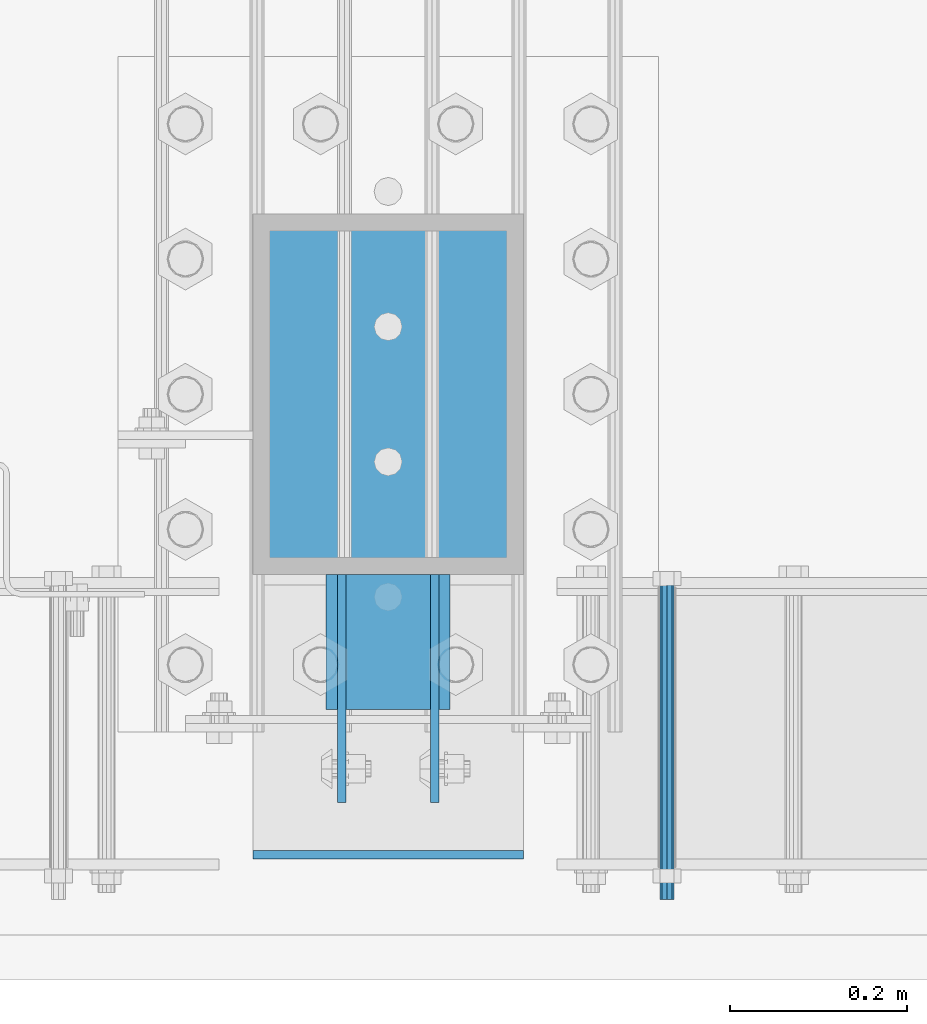
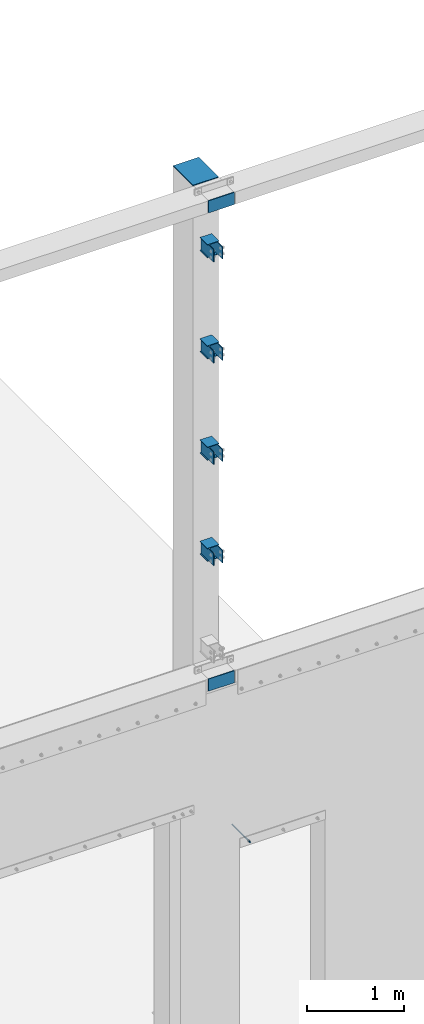
# One storey, part 1085 of 1876: 20 beams, 2 elements without a shape of their own.
"""IFC2X3 building model written with IfcOpenShell, lengths in millimetres."""

from ifc_helpers import new_model, si_unit, frame, origin_with_axes, place, context, subcontext, project, spatial, faceted_brep, material, type_object, element, aggregate, save


model = new_model("IFC2X3")

# Units and contexts
model_context = context("Model", 3, precision=1e-05, world=origin_with_axes())
body_context = subcontext(model_context, "Body", "Model", "MODEL_VIEW")
ifc_project = project(units=[si_unit("LENGTHUNIT", "METRE", prefix="MILLI"), si_unit("AREAUNIT", "SQUARE_METRE"), si_unit("VOLUMEUNIT", "CUBIC_METRE"), si_unit("MASSUNIT", "GRAM", prefix="KILO"), si_unit("TIMEUNIT", "SECOND"), si_unit("PLANEANGLEUNIT", "RADIAN"), si_unit("SOLIDANGLEUNIT", "STERADIAN"), si_unit("THERMODYNAMICTEMPERATUREUNIT", "DEGREE_CELSIUS"), si_unit("LUMINOUSINTENSITYUNIT", "LUMEN")], contexts=[model_context])

# Site, building, storey
site_placement = place(None, origin_with_axes())
site = spatial("IfcSite", under=ifc_project, at=site_placement, CompositionType="ELEMENT")
building_placement = place(site_placement, origin_with_axes())
building = spatial("IfcBuilding", under=site, at=building_placement, Name="Undefined", CompositionType="ELEMENT")
storey_placement = place(building_placement, origin_with_axes())
storey = spatial("IfcBuildingStorey", under=building, at=storey_placement, Name="Undefined", CompositionType="ELEMENT", Elevation=0.0)

# Assembly, beams
assembly_1_placement = place(storey_placement, origin_with_axes())
assembly_1 = element("IfcElementAssembly", 1, at=assembly_1_placement, inside=storey, Name="COLUMN", AssemblyPlace="NOTDEFINED", PredefinedType="RIGID_FRAME")
ifc_material = material(Name="STEEL/A36")
beam_type_1 = type_object("IfcBeamType", PredefinedType="NOTDEFINED")
beam_1_placement = place(assembly_1_placement, frame((3836.98749847411, -25603.2, 6097.5875), z_axis=(0.0, 0.0, -1.0), x_axis=(0.0, -1.0, 0.0)))
beam_1 = element("IfcBeam", 2, at=beam_1_placement, type_object=beam_type_1, material=ifc_material, Name="PLATE", context=body_context, shape_type="Brep", body=[
    faceted_brep([(0.0, 4.76249999999982, -76.1999999999998), (3.63797880709171e-12, 4.76249999999982, 76.1999969482422), (257.174999999999, 4.76249999999982, 76.1999999999998), (257.174999999999, 4.76249999999982, -76.1999999999998), (3.63797880709171e-12, -4.76249999999982, 76.1999969482422), (257.174999999999, -4.76249999999982, 76.1999999999998), (0.0, -4.76249999999982, -76.1999999999998), (257.174999999999, -4.76249999999982, -76.1999999999998)], [[[0, 1, 2, 3]], [[1, 4, 5, 2]], [[4, 6, 7, 5]], [[6, 0, 3, 7]], [[5, 7, 3, 2]], [[6, 4, 1, 0]]]),
])
beam_2_placement = place(assembly_1_placement, frame((3836.98749847411, -25603.2, 7366.52916666666), z_axis=(0.0, 0.0, -1.0), x_axis=(0.0, -1.0, 0.0)))
beam_2 = element("IfcBeam", 3, at=beam_2_placement, type_object=beam_type_1, material=ifc_material, Name="PLATE", context=body_context, shape_type="Brep", body=[
    faceted_brep([(0.0, 4.76249999999982, -76.1999999999998), (3.63797880709171e-12, 4.76249999999982, 76.1999969482422), (257.174999999999, 4.76249999999982, 76.1999999999998), (257.174999999999, 4.76249999999982, -76.1999999999998), (3.63797880709171e-12, -4.76249999999982, 76.1999969482422), (257.174999999999, -4.76249999999982, 76.1999999999998), (0.0, -4.76249999999982, -76.1999999999998), (257.174999999999, -4.76249999999982, -76.1999999999998)], [[[0, 1, 2, 3]], [[1, 4, 5, 2]], [[4, 6, 7, 5]], [[6, 0, 3, 7]], [[5, 7, 3, 2]], [[6, 4, 1, 0]]]),
])
beam_3_placement = place(assembly_1_placement, frame((3836.98749847411, -25603.2, 8635.47083333333), z_axis=(0.0, 0.0, -1.0), x_axis=(0.0, -1.0, 0.0)))
beam_3 = element("IfcBeam", 4, at=beam_3_placement, type_object=beam_type_1, material=ifc_material, Name="PLATE", context=body_context, shape_type="Brep", body=[
    faceted_brep([(0.0, 4.76249999999982, -76.1999999999998), (3.63797880709171e-12, 4.76249999999982, 76.1999969482422), (257.174999999999, 4.76249999999982, 76.1999999999998), (257.174999999999, 4.76249999999982, -76.1999999999998), (3.63797880709171e-12, -4.76249999999982, 76.1999969482422), (257.174999999999, -4.76249999999982, 76.1999999999998), (0.0, -4.76249999999982, -76.1999999999998), (257.174999999999, -4.76249999999982, -76.1999999999998)], [[[0, 1, 2, 3]], [[1, 4, 5, 2]], [[4, 6, 7, 5]], [[6, 0, 3, 7]], [[5, 7, 3, 2]], [[6, 4, 1, 0]]]),
])
beam_4_placement = place(assembly_1_placement, frame((3836.98749847411, -25603.2, 9904.41249999999), z_axis=(0.0, 0.0, -1.0), x_axis=(0.0, -1.0, 0.0)))
beam_4 = element("IfcBeam", 5, at=beam_4_placement, type_object=beam_type_1, material=ifc_material, Name="PLATE", context=body_context, shape_type="Brep", body=[
    faceted_brep([(0.0, 4.76249999999982, -76.1999999999998), (3.63797880709171e-12, 4.76249999999982, 76.1999969482422), (257.174999999999, 4.76249999999982, 76.1999999999998), (257.174999999999, 4.76249999999982, -76.1999999999998), (3.63797880709171e-12, -4.76249999999982, 76.1999969482422), (257.174999999999, -4.76249999999982, 76.1999999999998), (0.0, -4.76249999999982, -76.1999999999998), (257.174999999999, -4.76249999999982, -76.1999999999998)], [[[0, 1, 2, 3]], [[1, 4, 5, 2]], [[4, 6, 7, 5]], [[6, 0, 3, 7]], [[5, 7, 3, 2]], [[6, 4, 1, 0]]]),
])
beam_5_placement = place(assembly_1_placement, frame((3941.76249999999, -25603.2, 6097.5875), z_axis=(0.0, 0.0, -1.0), x_axis=(0.0, -1.0, 0.0)))
beam_5 = element("IfcBeam", 6, at=beam_5_placement, type_object=beam_type_1, material=ifc_material, Name="PLATE", context=body_context, shape_type="Brep", body=[
    faceted_brep([(0.0, 4.76249999999982, -76.1999999999998), (3.63797880709171e-12, 4.76249999999982, 76.1999969482422), (257.174999999999, 4.76249999999982, 76.1999999999998), (257.174999999999, 4.76249999999982, -76.1999999999998), (3.63797880709171e-12, -4.76249999999982, 76.1999969482422), (257.174999999999, -4.76249999999982, 76.1999999999998), (0.0, -4.76249999999982, -76.1999999999998), (257.174999999999, -4.76249999999982, -76.1999999999998)], [[[0, 1, 2, 3]], [[1, 4, 5, 2]], [[4, 6, 7, 5]], [[6, 0, 3, 7]], [[5, 7, 3, 2]], [[6, 4, 1, 0]]]),
])
beam_6_placement = place(assembly_1_placement, frame((3941.76249999999, -25603.2, 7366.52916666666), z_axis=(0.0, 0.0, -1.0), x_axis=(0.0, -1.0, 0.0)))
beam_6 = element("IfcBeam", 7, at=beam_6_placement, type_object=beam_type_1, material=ifc_material, Name="PLATE", context=body_context, shape_type="Brep", body=[
    faceted_brep([(0.0, 4.76249999999982, -76.1999999999998), (3.63797880709171e-12, 4.76249999999982, 76.1999969482422), (257.174999999999, 4.76249999999982, 76.1999999999998), (257.174999999999, 4.76249999999982, -76.1999999999998), (3.63797880709171e-12, -4.76249999999982, 76.1999969482422), (257.174999999999, -4.76249999999982, 76.1999999999998), (0.0, -4.76249999999982, -76.1999999999998), (257.174999999999, -4.76249999999982, -76.1999999999998)], [[[0, 1, 2, 3]], [[1, 4, 5, 2]], [[4, 6, 7, 5]], [[6, 0, 3, 7]], [[5, 7, 3, 2]], [[6, 4, 1, 0]]]),
])
beam_7_placement = place(assembly_1_placement, frame((3941.76249999999, -25603.2, 8635.47083333333), z_axis=(0.0, 0.0, -1.0), x_axis=(0.0, -1.0, 0.0)))
beam_7 = element("IfcBeam", 8, at=beam_7_placement, type_object=beam_type_1, material=ifc_material, Name="PLATE", context=body_context, shape_type="Brep", body=[
    faceted_brep([(0.0, 4.76249999999982, -76.1999999999998), (3.63797880709171e-12, 4.76249999999982, 76.1999969482422), (257.174999999999, 4.76249999999982, 76.1999999999998), (257.174999999999, 4.76249999999982, -76.1999999999998), (3.63797880709171e-12, -4.76249999999982, 76.1999969482422), (257.174999999999, -4.76249999999982, 76.1999999999998), (0.0, -4.76249999999982, -76.1999999999998), (257.174999999999, -4.76249999999982, -76.1999999999998)], [[[0, 1, 2, 3]], [[1, 4, 5, 2]], [[4, 6, 7, 5]], [[6, 0, 3, 7]], [[5, 7, 3, 2]], [[6, 4, 1, 0]]]),
])
beam_8_placement = place(assembly_1_placement, frame((3941.76249999999, -25603.2, 9904.41249999999), z_axis=(0.0, 0.0, -1.0), x_axis=(0.0, -1.0, 0.0)))
beam_8 = element("IfcBeam", 9, at=beam_8_placement, type_object=beam_type_1, material=ifc_material, Name="PLATE", context=body_context, shape_type="Brep", body=[
    faceted_brep([(0.0, 4.76249999999982, -76.1999999999998), (3.63797880709171e-12, 4.76249999999982, 76.1999969482422), (257.174999999999, 4.76249999999982, 76.1999999999998), (257.174999999999, 4.76249999999982, -76.1999999999998), (3.63797880709171e-12, -4.76249999999982, 76.1999969482422), (257.174999999999, -4.76249999999982, 76.1999999999998), (0.0, -4.76249999999982, -76.1999999999998), (257.174999999999, -4.76249999999982, -76.1999999999998)], [[[0, 1, 2, 3]], [[1, 4, 5, 2]], [[4, 6, 7, 5]], [[6, 0, 3, 7]], [[5, 7, 3, 2]], [[6, 4, 1, 0]]]),
])
beam_9_placement = place(assembly_1_placement, frame((4041.775, -25919.1125, 4597.4), z_axis=(0.0, 0.0, 1.0), x_axis=(-1.0, 0.0, 0.0)))
beam_9 = element("IfcBeam", 10, at=beam_9_placement, type_object=beam_type_1, material=ifc_material, Name="PLATE", context=body_context, shape_type="Brep", body=[
    faceted_brep([(0.0, 4.76249999999982, -76.1999999999998), (3.63797880709171e-12, 4.76249999999982, 76.1999969482422), (304.799999999999, 4.76250000000073, 76.1999999999998), (304.799999999999, 4.76250000000073, -76.1999999999998), (3.63797880709171e-12, -4.76249999999982, 76.1999969482422), (304.799999999999, -4.76250000000073, 76.1999999999998), (0.0, -4.76249999999982, -76.1999999999998), (304.799999999999, -4.76250000000073, -76.1999999999998)], [[[0, 1, 2, 3]], [[1, 4, 5, 2]], [[4, 6, 7, 5]], [[6, 0, 3, 7]], [[5, 7, 3, 2]], [[6, 4, 1, 0]]]),
])
beam_10_placement = place(assembly_1_placement, frame((4041.775, -25919.1125, 10591.8), z_axis=(0.0, 0.0, 1.0), x_axis=(-1.0, 0.0, 0.0)))
beam_10 = element("IfcBeam", 11, at=beam_10_placement, type_object=beam_type_1, material=ifc_material, Name="PLATE", context=body_context, shape_type="Brep", body=[
    faceted_brep([(0.0, 4.76249999999982, -76.1999999999998), (3.63797880709171e-12, 4.76249999999982, 76.1999969482422), (304.799999999999, 4.76250000000073, 76.1999999999998), (304.799999999999, 4.76250000000073, -76.1999999999998), (3.63797880709171e-12, -4.76249999999982, 76.1999969482422), (304.799999999999, -4.76250000000073, 76.1999999999998), (0.0, -4.76249999999982, -76.1999999999998), (304.799999999999, -4.76250000000073, -76.1999999999998)], [[[0, 1, 2, 3]], [[1, 4, 5, 2]], [[4, 6, 7, 5]], [[6, 0, 3, 7]], [[5, 7, 3, 2]], [[6, 4, 1, 0]]]),
])
beam_type_2 = type_object("IfcBeamType", PredefinedType="NOTDEFINED")
beam_11_placement = place(assembly_1_placement, frame((3889.375, -25603.2, 9825.0375), z_axis=(1.0, 0.0, 0.0), x_axis=(0.0, -1.0, 0.0)))
beam_11 = element("IfcBeam", 12, at=beam_11_placement, type_object=beam_type_2, material=ifc_material, Name="PLATE", context=body_context, shape_type="Brep", body=[
    faceted_brep([(0.0, 3.17500000000018, -69.8499999999999), (0.0, 3.17500000000018, 69.8499999999999), (152.400000000001, 3.17500000000018, 69.8499999999999), (152.400000000001, 3.17500000000018, -69.8499999999999), (0.0, -3.17500000000018, 69.8499999999999), (152.400000000001, -3.17500000000018, 69.8499999999999), (0.0, -3.17500000000018, -69.8499999999999), (152.400000000001, -3.17500000000018, -69.8499999999999)], [[[0, 1, 2, 3]], [[1, 4, 5, 2]], [[4, 6, 7, 5]], [[6, 0, 3, 7]], [[5, 7, 3, 2]], [[6, 4, 1, 0]]]),
])
beam_12_placement = place(assembly_1_placement, frame((3889.375, -25603.2, 9983.78749999999), z_axis=(1.0, 0.0, 0.0), x_axis=(0.0, -1.0, 0.0)))
beam_12 = element("IfcBeam", 13, at=beam_12_placement, type_object=beam_type_2, material=ifc_material, Name="PLATE", context=body_context, shape_type="Brep", body=[
    faceted_brep([(0.0, 3.17500000000018, -69.8499999999999), (0.0, 3.17500000000018, 69.8499999999999), (152.400000000001, 3.17500000000018, 69.8499999999999), (152.400000000001, 3.17500000000018, -69.8499999999999), (0.0, -3.17500000000018, 69.8499999999999), (152.400000000001, -3.17500000000018, 69.8499999999999), (0.0, -3.17500000000018, -69.8499999999999), (152.400000000001, -3.17500000000018, -69.8499999999999)], [[[0, 1, 2, 3]], [[1, 4, 5, 2]], [[4, 6, 7, 5]], [[6, 0, 3, 7]], [[5, 7, 3, 2]], [[6, 4, 1, 0]]]),
])
beam_13_placement = place(assembly_1_placement, frame((3889.375, -25603.2, 8556.09583333333), z_axis=(1.0, 0.0, 0.0), x_axis=(0.0, -1.0, 0.0)))
beam_13 = element("IfcBeam", 14, at=beam_13_placement, type_object=beam_type_2, material=ifc_material, Name="PLATE", context=body_context, shape_type="Brep", body=[
    faceted_brep([(0.0, 3.17500000000018, -69.8499999999999), (0.0, 3.17500000000018, 69.8499999999999), (152.400000000001, 3.17500000000018, 69.8499999999999), (152.400000000001, 3.17500000000018, -69.8499999999999), (0.0, -3.17500000000018, 69.8499999999999), (152.400000000001, -3.17500000000018, 69.8499999999999), (0.0, -3.17500000000018, -69.8499999999999), (152.400000000001, -3.17500000000018, -69.8499999999999)], [[[0, 1, 2, 3]], [[1, 4, 5, 2]], [[4, 6, 7, 5]], [[6, 0, 3, 7]], [[5, 7, 3, 2]], [[6, 4, 1, 0]]]),
])
beam_14_placement = place(assembly_1_placement, frame((3889.375, -25603.2, 8714.84583333333), z_axis=(1.0, 0.0, 0.0), x_axis=(0.0, -1.0, 0.0)))
beam_14 = element("IfcBeam", 15, at=beam_14_placement, type_object=beam_type_2, material=ifc_material, Name="PLATE", context=body_context, shape_type="Brep", body=[
    faceted_brep([(0.0, 3.17500000000018, -69.8499999999999), (0.0, 3.17500000000018, 69.8499999999999), (152.400000000001, 3.17500000000018, 69.8499999999999), (152.400000000001, 3.17500000000018, -69.8499999999999), (0.0, -3.17500000000018, 69.8499999999999), (152.400000000001, -3.17500000000018, 69.8499999999999), (0.0, -3.17500000000018, -69.8499999999999), (152.400000000001, -3.17500000000018, -69.8499999999999)], [[[0, 1, 2, 3]], [[1, 4, 5, 2]], [[4, 6, 7, 5]], [[6, 0, 3, 7]], [[5, 7, 3, 2]], [[6, 4, 1, 0]]]),
])
beam_15_placement = place(assembly_1_placement, frame((3889.375, -25603.2, 7287.15416666666), z_axis=(1.0, 0.0, 0.0), x_axis=(0.0, -1.0, 0.0)))
beam_15 = element("IfcBeam", 16, at=beam_15_placement, type_object=beam_type_2, material=ifc_material, Name="PLATE", context=body_context, shape_type="Brep", body=[
    faceted_brep([(0.0, 3.17500000000018, -69.8499999999999), (0.0, 3.17500000000018, 69.8499999999999), (152.400000000001, 3.17500000000018, 69.8499999999999), (152.400000000001, 3.17500000000018, -69.8499999999999), (0.0, -3.17500000000018, 69.8499999999999), (152.400000000001, -3.17500000000018, 69.8499999999999), (0.0, -3.17500000000018, -69.8499999999999), (152.400000000001, -3.17500000000018, -69.8499999999999)], [[[0, 1, 2, 3]], [[1, 4, 5, 2]], [[4, 6, 7, 5]], [[6, 0, 3, 7]], [[5, 7, 3, 2]], [[6, 4, 1, 0]]]),
])
beam_16_placement = place(assembly_1_placement, frame((3889.375, -25603.2, 7445.90416666666), z_axis=(1.0, 0.0, 0.0), x_axis=(0.0, -1.0, 0.0)))
beam_16 = element("IfcBeam", 17, at=beam_16_placement, type_object=beam_type_2, material=ifc_material, Name="PLATE", context=body_context, shape_type="Brep", body=[
    faceted_brep([(0.0, 3.17500000000018, -69.8499999999999), (0.0, 3.17500000000018, 69.8499999999999), (152.400000000001, 3.17500000000018, 69.8499999999999), (152.400000000001, 3.17500000000018, -69.8499999999999), (0.0, -3.17500000000018, 69.8499999999999), (152.400000000001, -3.17500000000018, 69.8499999999999), (0.0, -3.17500000000018, -69.8499999999999), (152.400000000001, -3.17500000000018, -69.8499999999999)], [[[0, 1, 2, 3]], [[1, 4, 5, 2]], [[4, 6, 7, 5]], [[6, 0, 3, 7]], [[5, 7, 3, 2]], [[6, 4, 1, 0]]]),
])
beam_17_placement = place(assembly_1_placement, frame((3889.375, -25603.2, 6018.2125), z_axis=(1.0, 0.0, 0.0), x_axis=(0.0, -1.0, 0.0)))
beam_17 = element("IfcBeam", 18, at=beam_17_placement, type_object=beam_type_2, material=ifc_material, Name="PLATE", context=body_context, shape_type="Brep", body=[
    faceted_brep([(0.0, 3.17500000000018, -69.8499999999999), (0.0, 3.17500000000018, 69.8499999999999), (152.400000000001, 3.17500000000018, 69.8499999999999), (152.400000000001, 3.17500000000018, -69.8499999999999), (0.0, -3.17500000000018, 69.8499999999999), (152.400000000001, -3.17500000000018, 69.8499999999999), (0.0, -3.17500000000018, -69.8499999999999), (152.400000000001, -3.17500000000018, -69.8499999999999)], [[[0, 1, 2, 3]], [[1, 4, 5, 2]], [[4, 6, 7, 5]], [[6, 0, 3, 7]], [[5, 7, 3, 2]], [[6, 4, 1, 0]]]),
])
beam_18_placement = place(assembly_1_placement, frame((3889.375, -25603.2, 6176.9625), z_axis=(1.0, 0.0, 0.0), x_axis=(0.0, -1.0, 0.0)))
beam_18 = element("IfcBeam", 19, at=beam_18_placement, type_object=beam_type_2, material=ifc_material, Name="PLATE", context=body_context, shape_type="Brep", body=[
    faceted_brep([(0.0, 3.17500000000018, -69.8499999999999), (0.0, 3.17500000000018, 69.8499999999999), (152.400000000001, 3.17500000000018, 69.8499999999999), (152.400000000001, 3.17500000000018, -69.8499999999999), (0.0, -3.17500000000018, 69.8499999999999), (152.400000000001, -3.17500000000018, 69.8499999999999), (0.0, -3.17500000000018, -69.8499999999999), (152.400000000001, -3.17500000000018, -69.8499999999999)], [[[0, 1, 2, 3]], [[1, 4, 5, 2]], [[4, 6, 7, 5]], [[6, 0, 3, 7]], [[5, 7, 3, 2]], [[6, 4, 1, 0]]]),
])

# Assembly, beam
assembly_2_placement = place(storey_placement, origin_with_axes())
assembly_2 = element("IfcElementAssembly", 20, at=assembly_2_placement, inside=storey, Name="ANCHOR_BOLT", AssemblyPlace="NOTDEFINED", PredefinedType="RIGID_FRAME")
beam_type_3 = type_object("IfcBeamType", PredefinedType="NOTDEFINED")
beam_19_placement = place(assembly_2_placement, frame((4203.70979190826, -25969.9124969811, 2493.96240386963), z_axis=(0.0, 0.0, 1.0), x_axis=(-2.91149999876944e-05, 0.999999999576158, 0.0)))
beam_19 = element("IfcBeam", 21, at=beam_19_placement, type_object=beam_type_3, material=ifc_material, Name="ANCHOR_BOLT", context=body_context, shape_type="Brep", body=[
    faceted_brep([(0.0, -7.9375, 0.0), (0.0, -5.61266007566822, -5.61266007566883), (369.887490732475, -5.61266007567792, -5.61266007566837), (369.887490732477, -7.93750000000978, 0.0), (0.0, 0.0, -7.9375), (369.88749073247, -9.54969436861575e-12, -7.9375), (0.0, 5.61266007566822, -5.61266007566883), (369.887490732464, 5.6126600756586, -5.61266007566837), (0.0, 7.9375, 0.0), (369.887490732463, 7.93749999999045, 0.0), (0.0, 5.61266007566822, 5.61266007566883), (369.887490732464, 5.6126600756586, 5.61266007566837), (0.0, 0.0, 7.9375), (369.88749073247, -9.54969436861575e-12, 7.9375), (0.0, -5.61266007566822, 5.61266007566883), (369.887490732475, -5.61266007567792, 5.61266007566837)], [[[0, 1, 2, 3]], [[1, 4, 5, 2]], [[4, 6, 7, 5]], [[6, 8, 9, 7]], [[8, 10, 11, 9]], [[10, 12, 13, 11]], [[12, 14, 15, 13]], [[14, 0, 3, 15]], [[5, 7, 9, 11, 13, 15, 3, 2]], [[14, 12, 10, 8, 6, 4, 1, 0]]]),
])
aggregate(assembly_2, [beam_19])

# Beam
beam_type_4 = type_object("IfcBeamType", PredefinedType="NOTDEFINED")
beam_20_placement = place(assembly_1_placement, frame((3889.375, -25603.2, 10663.2375), z_axis=(1.0, 0.0, 0.0), x_axis=(0.0, 1.0, 0.0)))
beam_20 = element("IfcBeam", 22, at=beam_20_placement, type_object=beam_type_4, material=ifc_material, Name="PLATE", context=body_context, shape_type="Brep", body=[
    faceted_brep([(0.0, 4.76250000000073, -152.4), (0.0, 4.76250000000073, 152.4), (406.400000000001, 4.76250000000073, 152.4), (406.400000000001, 4.76250000000073, -152.4), (0.0, -4.76250000000073, 152.4), (406.400000000001, -4.76250000000073, 152.4), (0.0, -4.76250000000073, -152.4), (406.400000000001, -4.76250000000073, -152.4)], [[[0, 1, 2, 3]], [[1, 4, 5, 2]], [[4, 6, 7, 5]], [[6, 0, 3, 7]], [[5, 7, 3, 2]], [[6, 4, 1, 0]]]),
])

aggregate(assembly_1, [beam_11, beam_12, beam_13, beam_14, beam_15, beam_16, beam_17, beam_18, beam_1, beam_2, beam_3, beam_4, beam_5, beam_6, beam_7, beam_8, beam_20, beam_9, beam_10])

save(model, "model.ifc")
